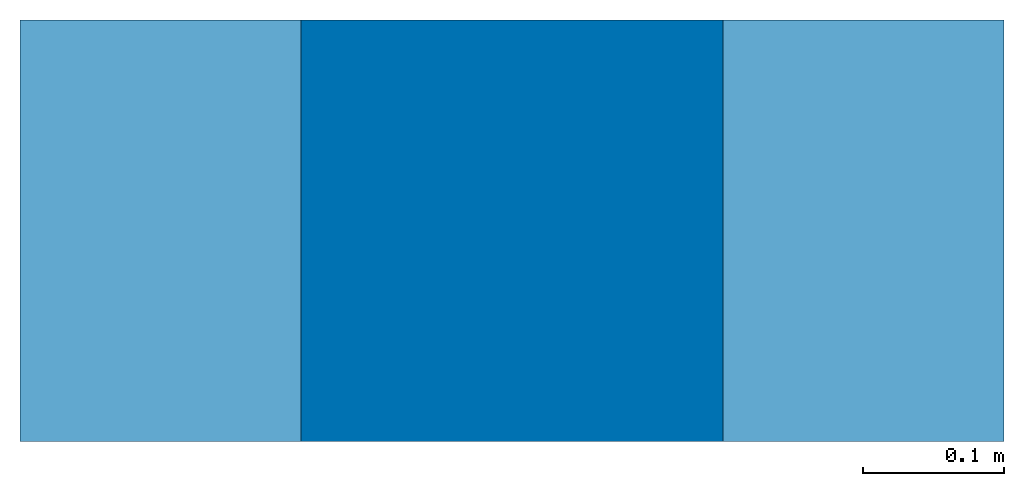
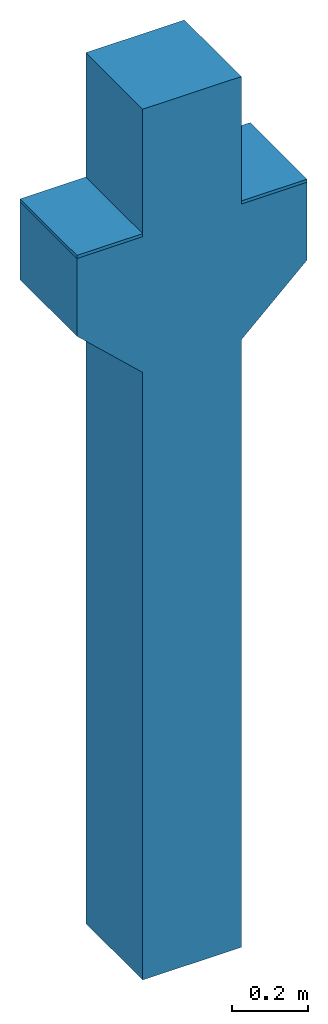
# One storey: 1 column, 1 discrete accessory.
"""IFC4 building model written with IfcOpenShell, lengths in centimetres."""

from ifc_helpers import new_model, si_unit, frame, origin_with_axes, place, context, subcontext, project, spatial, polygons, source, transform, mapped, element, save


model = new_model("IFC4")

# Units and contexts
model_context = context("Model", 3, precision=1e-05, world=origin_with_axes())
plan_context = context("Plan", 2, precision=1e-05, world=origin_with_axes())
body_context = subcontext(model_context, "Body", "Model", "MODEL_VIEW")
ifc_project = project(units=[si_unit("LENGTHUNIT", "METRE", prefix="CENTI"), si_unit("AREAUNIT", "SQUARE_METRE", prefix="CENTI"), si_unit("VOLUMEUNIT", "CUBIC_METRE", prefix="CENTI")], contexts=[model_context, plan_context])

# Site, building, storey
site_placement = place(None, frame((1288.70067596436, 2573.25820922852, 0.0), z_axis=(0.0, 0.0, 1.0), x_axis=(1.0, 0.0, 0.0)))
site = spatial("IfcSite", under=ifc_project, at=site_placement)
building_placement = place(site_placement, origin_with_axes())
building = spatial("IfcBuilding", under=site, at=building_placement, Name="Default")
storey_placement = place(building_placement, frame((0.0, 0.0, 1.9145924429198e-09), z_axis=(0.0, 0.0, 1.0), x_axis=(1.0, 0.0, 0.0)))
storey = spatial("IfcBuildingStorey", under=building, at=storey_placement, Name="0")

# Column
shared_shape_1 = source(origin_with_axes(), body_context, "Body", "Tessellation", [
    polygons([(35.0, -15.0000009536743, 239.000015258789), (35.0, -15.0000009536743, 214.000015258789), (35.0, 15.0000009536743, 214.000015258789), (35.0, 15.0000009536743, 239.000015258789), (15.0000009536743, -15.0000009536743, 195.359008789063), (15.0000009536743, -15.0000009536743, 239.000015258789), (15.0000009536743, -15.0000009536743, 280.0), (-15.0000009536743, -15.0000009536743, 280.0), (-15.0000009536743, -15.0000009536743, 239.000015258789), (-35.0, -15.0000009536743, 239.000015258789), (-35.0, -15.0000009536743, 214.000015258789), (-15.0000009536743, -15.0000009536743, 195.359008789063), (-15.0000009536743, -15.0000009536743, 1.91461735354892e-09), (15.0000009536743, -15.0000009536743, 1.91461735354892e-09), (15.0000009536743, 15.0000009536743, 280.0), (15.0000009536743, 15.0000009536743, 239.000015258789), (-15.0000009536743, 15.0000009536743, 280.0), (-15.0000009536743, 15.0000009536743, 239.000015258789), (-35.0, 15.0000009536743, 239.000015258789), (-35.0, 15.0000009536743, 214.000015258789), (-15.0000009536743, 15.0000009536743, 195.359008789063), (-15.0000009536743, 15.0000009536743, 1.91461735354892e-09), (15.0000009536743, 15.0000009536743, 195.359008789063), (15.0000009536743, 15.0000009536743, 1.91461735354892e-09)], [[[7, 8, 9, 6]], [[2, 1, 6]], [[23, 3, 2, 5]], [[5, 2, 6]], [[5, 12, 13, 14]], [[11, 9, 10]], [[11, 12, 9]], [[6, 16, 15, 7]], [[17, 18, 9, 8]], [[19, 20, 11, 10]], [[21, 22, 13, 12]], [[5, 14, 24, 23]], [[14, 13, 22, 24]], [[22, 21, 23, 24]], [[18, 19, 10, 9]], [[18, 21, 20]], [[18, 20, 19]], [[16, 3, 23]], [[15, 16, 18, 17]], [[4, 3, 16]], [[4, 16, 6, 1]], [[8, 7, 15, 17]], [[20, 21, 12, 11]], [[21, 18, 16, 23]], [[12, 5, 6, 9]], [[3, 4, 1, 2]]]),
])
column_placement = place(storey_placement, frame((490.817070007324, 154.51774597168, -3.82918488583961e-09), z_axis=(0.0, 0.0, 1.0), x_axis=(1.0, 0.0, 0.0)))
element("IfcColumn", 1, at=column_placement, inside=storey, PredefinedType="COLUMN", context=body_context, shape_type="MappedRepresentation", body=[
    mapped(shared_shape_1, transform((0.0, 0.0, 0.0), x_axis=(1.0, 0.0, 0.0), y_axis=(0.0, 1.0, 0.0), z_axis=(0.0, 0.0, 1.0), scale=1.0)),
])

# Discrete accessory
shared_shape_2 = source(origin_with_axes(), body_context, "Body", "Tessellation", [
    polygons([(525.816955566406, 139.517532348633, 239.000015258789), (525.816955566406, 139.517532348633, 240.000015258789), (525.816955566406, 169.517547607422, 239.000015258789), (525.816955566406, 169.517547607422, 240.000015258789), (505.816986083984, 169.517547607422, 239.000015258789), (505.816986083984, 169.517547607422, 240.000015258789), (505.816986083984, 139.517532348633, 239.000015258789), (505.816986083984, 139.517532348633, 240.000015258789), (475.816955566406, 139.517532348633, 239.000015258789), (475.816955566406, 139.517532348633, 240.000015258789), (475.816955566406, 169.517547607422, 239.000015258789), (475.816955566406, 169.517547607422, 240.000015258789), (455.816986083984, 169.517547607422, 239.000015258789), (455.816986083984, 169.517547607422, 240.000015258789), (455.816986083984, 139.517532348633, 239.000015258789), (455.816986083984, 139.517532348633, 240.000015258789)], [[[6, 4, 3, 5]], [[8, 6, 5, 7]], [[2, 8, 7, 1]], [[1, 7, 5, 3]], [[6, 8, 2, 4]], [[12, 10, 9, 11]], [[14, 12, 11, 13]], [[16, 14, 13, 15]], [[10, 16, 15, 9]], [[9, 15, 13, 11]], [[14, 16, 10, 12]], [[4, 2, 1, 3]]]),
])
discrete_accessory_placement = place(storey_placement, frame((9.5367431640625e-05, 0.00019073486328125, -1.9145924429198e-09), z_axis=(0.0, 0.0, 1.0), x_axis=(1.0, 0.0, 0.0)))
element("IfcDiscreteAccessory", 2, at=discrete_accessory_placement, inside=storey, PredefinedType="USERDEFINED", context=body_context, shape_type="MappedRepresentation", body=[
    mapped(shared_shape_2, transform((0.0, 0.0, 0.0), x_axis=(1.0, 0.0, 0.0), y_axis=(0.0, 1.0, 0.0), z_axis=(0.0, 0.0, 1.0), scale=1.0)),
])

save(model, "model.ifc")
